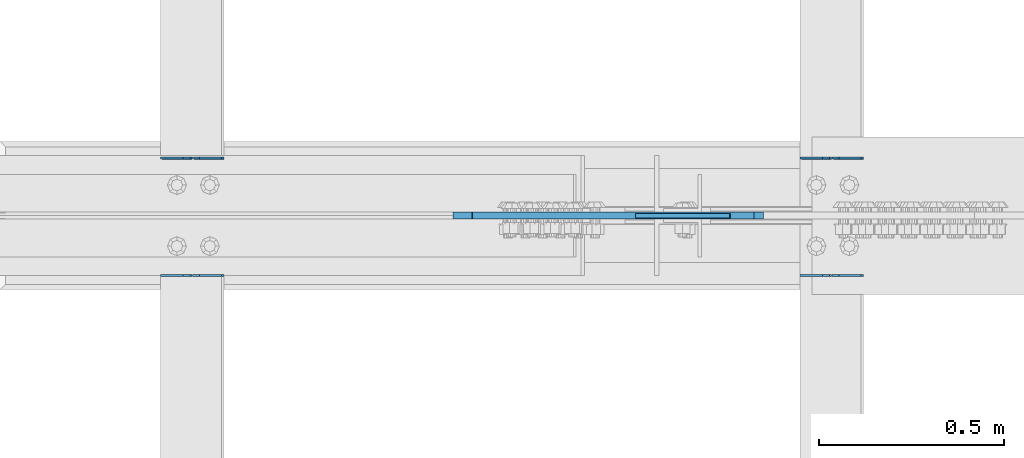
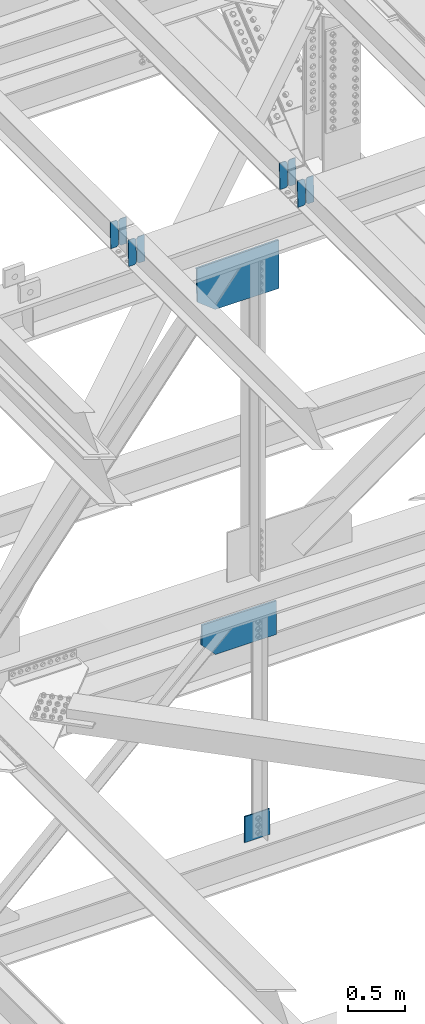
# One storey, part 3603 of 3843: 11 plates, 7 elements without a shape of their own.
"""IFC2X3 building model written with IfcOpenShell, lengths in millimetres."""

from ifc_helpers import new_model, si_unit, frame, origin_with_axes, place, context, subcontext, project, spatial, faceted_brep, material, type_object, element, aggregate, save


model = new_model("IFC2X3")

# Units and contexts
model_context = context("Model", 3, precision=1e-05, world=origin_with_axes())
body_context = subcontext(model_context, "Body", "Model", "MODEL_VIEW")
ifc_project = project(units=[si_unit("LENGTHUNIT", "METRE", prefix="MILLI"), si_unit("AREAUNIT", "SQUARE_METRE"), si_unit("VOLUMEUNIT", "CUBIC_METRE"), si_unit("MASSUNIT", "GRAM", prefix="KILO"), si_unit("TIMEUNIT", "SECOND"), si_unit("PLANEANGLEUNIT", "RADIAN"), si_unit("SOLIDANGLEUNIT", "STERADIAN"), si_unit("THERMODYNAMICTEMPERATUREUNIT", "DEGREE_CELSIUS"), si_unit("LUMINOUSINTENSITYUNIT", "LUMEN")], contexts=[model_context])

# Site, building, storey
site_placement = place(None, origin_with_axes())
site = spatial("IfcSite", under=ifc_project, at=site_placement, CompositionType="ELEMENT")
building_placement = place(site_placement, origin_with_axes())
building = spatial("IfcBuilding", under=site, at=building_placement, Name="Undefined", CompositionType="ELEMENT")
storey_placement = place(building_placement, origin_with_axes())
storey = spatial("IfcBuildingStorey", under=building, at=storey_placement, Name="Undefined", CompositionType="ELEMENT", Elevation=0.0)

# Assembly, plates
assembly_1_placement = place(storey_placement, origin_with_axes())
assembly_1 = element("IfcElementAssembly", 1, at=assembly_1_placement, inside=storey, Name="BEAM", AssemblyPlace="NOTDEFINED", PredefinedType="RIGID_FRAME")
ifc_material = material(Name="STEEL/A572-50")
plate_type_1 = type_object("IfcPlateType", PredefinedType="NOTDEFINED")
plate_1_placement = place(assembly_1_placement, frame((80549.4964818022, 59070.6862808835, 46449.4723570783), z_axis=(-0.0211520982257644, 0.00063245100018685, 0.999776069300711), x_axis=(-0.999776269350183, -1.43399999262055e-05, -0.021152093007418)))
plate_1 = element("IfcPlate", 2, at=plate_1_placement, type_object=plate_type_1, material=ifc_material, Name="PLATE", context=body_context, shape_type="Brep", body=[
    faceted_brep([(0.0, -3.17499999999927, 0.0), (6.83940015733242e-10, -3.17499999996653, 288.924999998613), (6.54836185276508e-10, 3.17500000001746, 288.924999998591), (0.0, 3.17499999999927, 0.0), (60.3250007643655, -3.17500000017753, 288.924999998606), (60.3250007643219, 3.17499999979918, 288.924999998584), (79.3750000013097, -3.17500000025029, 269.875000761494), (79.375000001266, 3.17499999972642, 269.875000761487), (79.375000000713, -3.17500000026484, 19.0499992370605), (79.3750000006985, 3.17499999971187, 19.0499992370533), (60.325000763667, -3.17500000020664, -1.45519152283669e-11), (60.3250007636234, 3.17499999977736, -3.63797880709171e-11)], [[[0, 1, 2, 3]], [[1, 4, 5, 2]], [[4, 6, 7, 5]], [[6, 8, 9, 7]], [[8, 10, 11, 9]], [[10, 0, 3, 11]], [[5, 7, 9, 11, 3, 2]], [[10, 8, 6, 4, 1, 0]]]),
])
plate_2_placement = place(assembly_1_placement, frame((80463.7906611109, 59070.6851357132, 46447.6590938386), z_axis=(-0.0211520982257644, 0.00063245100018685, 0.999776069300711), x_axis=(-0.999776269350183, -1.43399999262055e-05, -0.021152093007418)))
plate_2 = element("IfcPlate", 3, at=plate_2_placement, type_object=plate_type_1, material=ifc_material, Name="PLATE", context=body_context, shape_type="Brep", body=[
    faceted_brep([(4.36557456851006e-11, -3.17499999998836, 19.0499992370969), (6.11180439591408e-10, -3.17499999996653, 269.875000761516), (5.96628524363041e-10, 3.17500000001746, 269.875000761502), (1.45519152283669e-11, 3.17499999998836, 19.0499992370824), (19.0499992376572, -3.17500000003201, 288.924999998606), (19.0499992376281, 3.1749999999447, 288.924999998584), (79.3750000013242, -3.17500000025029, 288.924999998591), (79.3750000013097, 3.1749999997337, 288.92499999857), (79.3750000006548, -3.17500000026484, -2.18278728425503e-11), (79.3750000006403, 3.17499999969732, -2.91038304567337e-11), (19.0499992370023, -3.17500000005384, 0.0), (19.0499992369587, 3.17499999992287, -1.45519152283669e-11)], [[[0, 1, 2, 3]], [[1, 4, 5, 2]], [[4, 6, 7, 5]], [[6, 8, 9, 7]], [[8, 10, 11, 9]], [[10, 0, 3, 11]], [[5, 7, 9, 11, 3, 2]], [[10, 8, 6, 4, 1, 0]]]),
])
aggregate(assembly_1, [plate_1, plate_2])

assembly_2_placement = place(storey_placement, origin_with_axes())
assembly_2 = element("IfcElementAssembly", 4, at=assembly_2_placement, inside=storey, Name="BEAM", AssemblyPlace="NOTDEFINED", PredefinedType="RIGID_FRAME")
plate_3_placement = place(assembly_2_placement, frame((80549.4964783693, 58753.5631013965, 46449.4695674323), z_axis=(-0.021152098138482, -0.000624861000040255, 0.999776074075125), x_axis=(-0.999776269355722, 1.23390000256453e-05, -0.0211520940075457)))
plate_3 = element("IfcPlate", 5, at=plate_3_placement, type_object=plate_type_1, material=ifc_material, Name="PLATE", context=body_context, shape_type="Brep", body=[
    faceted_brep([(0.0, -3.17499999999927, 0.0), (6.83940015733242e-10, -3.17499999996653, 288.924999998613), (6.54836185276508e-10, 3.17500000001746, 288.924999998591), (0.0, 3.17499999999927, 0.0), (60.3250007643655, -3.17500000017753, 288.924999998606), (60.3250007643219, 3.17499999979918, 288.924999998584), (79.3750000013097, -3.17500000025029, 269.875000761494), (79.375000001266, 3.17499999972642, 269.875000761487), (79.375000000713, -3.17500000026484, 19.0499992370605), (79.3750000006985, 3.17499999971187, 19.0499992370533), (60.325000763667, -3.17500000020664, -1.45519152283669e-11), (60.3250007636234, 3.17499999977736, -3.63797880709171e-11)], [[[0, 1, 2, 3]], [[1, 4, 5, 2]], [[4, 6, 7, 5]], [[6, 8, 9, 7]], [[8, 10, 11, 9]], [[10, 0, 3, 11]], [[5, 7, 9, 11, 3, 2]], [[10, 8, 6, 4, 1, 0]]]),
])
plate_4_placement = place(assembly_2_placement, frame((80463.7906576781, 58753.564234688, 46447.6563041856), z_axis=(-0.021152098138482, -0.000624861000040255, 0.999776074075125), x_axis=(-0.999776269355722, 1.23390000256453e-05, -0.0211520940075457)))
plate_4 = element("IfcPlate", 6, at=plate_4_placement, type_object=plate_type_1, material=ifc_material, Name="PLATE", context=body_context, shape_type="Brep", body=[
    faceted_brep([(4.36557456851006e-11, -3.17499999998836, 19.0499992370969), (6.11180439591408e-10, -3.17499999996653, 269.875000761516), (5.96628524363041e-10, 3.17500000001746, 269.875000761502), (1.45519152283669e-11, 3.17499999998836, 19.0499992370824), (19.0499992376572, -3.17500000003201, 288.924999998606), (19.0499992376281, 3.1749999999447, 288.924999998584), (79.3750000013242, -3.17500000025029, 288.924999998591), (79.3750000013097, 3.1749999997337, 288.92499999857), (79.3750000006548, -3.17500000026484, -2.18278728425503e-11), (79.3750000006403, 3.17499999969732, -2.91038304567337e-11), (19.0499992370023, -3.17500000005384, 0.0), (19.0499992369587, 3.17499999992287, -1.45519152283669e-11)], [[[0, 1, 2, 3]], [[1, 4, 5, 2]], [[4, 6, 7, 5]], [[6, 8, 9, 7]], [[8, 10, 11, 9]], [[10, 0, 3, 11]], [[5, 7, 9, 11, 3, 2]], [[10, 8, 6, 4, 1, 0]]]),
])
aggregate(assembly_2, [plate_3, plate_4])

assembly_3_placement = place(storey_placement, origin_with_axes())
assembly_3 = element("IfcElementAssembly", 7, at=assembly_3_placement, inside=storey, Name="BEAM", AssemblyPlace="NOTDEFINED", PredefinedType="RIGID_FRAME")
plate_5_placement = place(assembly_3_placement, frame((78822.2964818254, 59070.6940089604, 46415.5716852855), z_axis=(-0.0211520978869958, 0.000606560000211177, 0.999776085351088), x_axis=(-0.999776269355723, -1.23390000258365e-05, -0.0211520940075068)))
plate_5 = element("IfcPlate", 8, at=plate_5_placement, type_object=plate_type_1, material=ifc_material, Name="PLATE", context=body_context, shape_type="Brep", body=[
    faceted_brep([(0.0, -3.17499999999927, 0.0), (6.83940015733242e-10, -3.17499999996653, 288.924999998613), (6.54836185276508e-10, 3.17500000001746, 288.924999998591), (0.0, 3.17499999999927, 0.0), (60.3250007643655, -3.17500000017753, 288.924999998606), (60.3250007643219, 3.17499999979918, 288.924999998584), (79.3750000013097, -3.17500000025029, 269.875000761494), (79.375000001266, 3.17499999972642, 269.875000761487), (79.375000000713, -3.17500000026484, 19.0499992370605), (79.3750000006985, 3.17499999971187, 19.0499992370533), (60.325000763667, -3.17500000020664, -1.45519152283669e-11), (60.3250007636234, 3.17499999977736, -3.63797880709171e-11)], [[[0, 1, 2, 3]], [[1, 4, 5, 2]], [[4, 6, 7, 5]], [[6, 8, 9, 7]], [[8, 10, 11, 9]], [[10, 0, 3, 11]], [[5, 7, 9, 11, 3, 2]], [[10, 8, 6, 4, 1, 0]]]),
])
plate_6_placement = place(assembly_3_placement, frame((78736.5906611341, 59070.6929107476, 46413.758422016), z_axis=(-0.0211520978869958, 0.000606560000211177, 0.999776085351088), x_axis=(-0.999776269355723, -1.23390000258365e-05, -0.0211520940075068)))
plate_6 = element("IfcPlate", 9, at=plate_6_placement, type_object=plate_type_1, material=ifc_material, Name="PLATE", context=body_context, shape_type="Brep", body=[
    faceted_brep([(4.36557456851006e-11, -3.17499999998836, 19.0499992370969), (6.11180439591408e-10, -3.17499999996653, 269.875000761516), (5.96628524363041e-10, 3.17500000001746, 269.875000761502), (1.45519152283669e-11, 3.17499999998836, 19.0499992370824), (19.0499992376572, -3.17500000003201, 288.924999998606), (19.0499992376281, 3.1749999999447, 288.924999998584), (79.3750000013242, -3.17500000025029, 288.924999998591), (79.3750000013097, 3.1749999997337, 288.92499999857), (79.3750000006548, -3.17500000026484, -2.18278728425503e-11), (79.3750000006403, 3.17499999969732, -2.91038304567337e-11), (19.0499992370023, -3.17500000005384, 0.0), (19.0499992369587, 3.17499999992287, -1.45519152283669e-11)], [[[0, 1, 2, 3]], [[1, 4, 5, 2]], [[4, 6, 7, 5]], [[6, 8, 9, 7]], [[8, 10, 11, 9]], [[10, 0, 3, 11]], [[5, 7, 9, 11, 3, 2]], [[10, 8, 6, 4, 1, 0]]]),
])
aggregate(assembly_3, [plate_5, plate_6])

assembly_4_placement = place(storey_placement, origin_with_axes())
assembly_4 = element("IfcElementAssembly", 10, at=assembly_4_placement, inside=storey, Name="BEAM", AssemblyPlace="NOTDEFINED", PredefinedType="RIGID_FRAME")
plate_7_placement = place(assembly_4_placement, frame((78822.2964783698, 58753.5266743956, 46415.5837070154), z_axis=(-0.021152097741724, -0.000508339000058186, 0.99977614011967), x_axis=(-0.999776269357268, 1.0337000006824e-05, -0.0211520950075907)))
plate_7 = element("IfcPlate", 11, at=plate_7_placement, type_object=plate_type_1, material=ifc_material, Name="PLATE", context=body_context, shape_type="Brep", body=[
    faceted_brep([(0.0, -3.17499999999927, 0.0), (6.83940015733242e-10, -3.17499999996653, 288.924999998613), (6.54836185276508e-10, 3.17500000001746, 288.924999998591), (0.0, 3.17499999999927, 0.0), (60.3250007643655, -3.17500000017753, 288.924999998606), (60.3250007643219, 3.17499999979918, 288.924999998584), (79.3750000013097, -3.17500000025029, 269.875000761494), (79.375000001266, 3.17499999972642, 269.875000761487), (79.375000000713, -3.17500000026484, 19.0499992370605), (79.3750000006985, 3.17499999971187, 19.0499992370533), (60.325000763667, -3.17500000020664, -1.45519152283669e-11), (60.3250007636234, 3.17499999977736, -3.63797880709171e-11)], [[[0, 1, 2, 3]], [[1, 4, 5, 2]], [[4, 6, 7, 5]], [[6, 8, 9, 7]], [[8, 10, 11, 9]], [[10, 0, 3, 11]], [[5, 7, 9, 11, 3, 2]], [[10, 8, 6, 4, 1, 0]]]),
])
plate_8_placement = place(assembly_4_placement, frame((78736.5906576786, 58753.5275963541, 46413.770443649), z_axis=(-0.021152097741724, -0.000508339000058186, 0.99977614011967), x_axis=(-0.999776269357268, 1.0337000006824e-05, -0.0211520950075907)))
plate_8 = element("IfcPlate", 12, at=plate_8_placement, type_object=plate_type_1, material=ifc_material, Name="PLATE", context=body_context, shape_type="Brep", body=[
    faceted_brep([(4.36557456851006e-11, -3.17499999998836, 19.0499992370969), (6.11180439591408e-10, -3.17499999996653, 269.875000761516), (5.96628524363041e-10, 3.17500000001746, 269.875000761502), (1.45519152283669e-11, 3.17499999998836, 19.0499992370824), (19.0499992376572, -3.17500000003201, 288.924999998606), (19.0499992376281, 3.1749999999447, 288.924999998584), (79.3750000013242, -3.17500000025029, 288.924999998591), (79.3750000013097, 3.1749999997337, 288.92499999857), (79.3750000006548, -3.17500000026484, -2.18278728425503e-11), (79.3750000006403, 3.17499999969732, -2.91038304567337e-11), (19.0499992370023, -3.17500000005384, 0.0), (19.0499992369587, 3.17499999992287, -1.45519152283669e-11)], [[[0, 1, 2, 3]], [[1, 4, 5, 2]], [[4, 6, 7, 5]], [[6, 8, 9, 7]], [[8, 10, 11, 9]], [[10, 0, 3, 11]], [[5, 7, 9, 11, 3, 2]], [[10, 8, 6, 4, 1, 0]]]),
])
aggregate(assembly_4, [plate_7, plate_8])

# Assembly, plate
assembly_5_placement = place(storey_placement, origin_with_axes())
assembly_5 = element("IfcElementAssembly", 13, at=assembly_5_placement, inside=storey, Name="BEAM", AssemblyPlace="NOTDEFINED", PredefinedType="RIGID_FRAME")
plate_type_2 = type_object("IfcPlateType", PredefinedType="NOTDEFINED")
plate_9_placement = place(assembly_5_placement, frame((80279.4954825506, 58915.3, 46039.2903585868), z_axis=(0.0191252529927733, 0.0, -0.999817095621976), x_axis=(-0.999817095621976, 0.0, -0.0191252529927674)))
plate_9 = element("IfcPlate", 14, at=plate_9_placement, type_object=plate_type_2, material=ifc_material, Name="PLATE", context=body_context, shape_type="Brep", body=[
    faceted_brep([(0.0, -9.52500000000146, 0.0), (9.636566826739, -9.52500000000146, 523.617760637841), (9.636566826739, 9.52500000000146, 523.617760637841), (0.0, 9.52500000000146, 0.0), (661.023736043833, -9.52500000000146, 511.157537448904), (661.023736043833, 9.52500000000146, 511.157537448904), (838.228057231056, -9.52500000000146, 366.739433427843), (838.228057231056, 9.52500000000146, 366.739433427843), (838.228057230386, -9.52500000000146, -1.20780896395445e-09), (838.228057230386, 9.52500000000146, -1.20780896395445e-09)], [[[0, 1, 2, 3]], [[1, 4, 5, 2]], [[4, 6, 7, 5]], [[6, 8, 9, 7]], [[8, 0, 3, 9]], [[5, 7, 9, 3, 2]], [[8, 6, 4, 1, 0]]]),
])
aggregate(assembly_5, [plate_9])

assembly_6_placement = place(storey_placement, origin_with_axes())
assembly_6 = element("IfcElementAssembly", 15, at=assembly_6_placement, inside=storey, Name="BEAM", AssemblyPlace="NOTDEFINED", PredefinedType="RIGID_FRAME")
plate_type_3 = type_object("IfcPlateType", PredefinedType="NOTDEFINED")
plate_10_placement = place(assembly_6_placement, frame((80254.4766041645, 58915.3, 42152.4391227326), z_axis=(-0.00202086100011366, 0.0, -0.999997958058324), x_axis=(-0.999997958058324, 0.0, 0.00202086100011715)))
plate_10 = element("IfcPlate", 16, at=plate_10_placement, type_object=plate_type_3, material=ifc_material, Name="PLATE", context=body_context, shape_type="Brep", body=[
    faceted_brep([(0.0, -9.52500000000146, 0.0), (-0.731130305459374, -9.52500000000146, 362.584599088834), (-0.731130305459374, 9.52500000000146, 362.584599088834), (0.0, 9.52500000000146, 0.0), (621.037847735905, -9.52500000000146, 363.181308734034), (621.037847735905, 9.52500000000146, 363.181308734034), (761.525667838927, -9.52500000000146, 215.616435646261), (761.525667838927, 9.52500000000146, 215.616435646261), (761.525667840455, -9.52500000000146, -1.67347025126219e-10), (761.525667840455, 9.52500000000146, -1.67347025126219e-10)], [[[0, 1, 2, 3]], [[1, 4, 5, 2]], [[4, 6, 7, 5]], [[6, 8, 9, 7]], [[8, 0, 3, 9]], [[5, 7, 9, 3, 2]], [[8, 6, 4, 1, 0]]]),
])
aggregate(assembly_6, [plate_10])

assembly_7_placement = place(storey_placement, origin_with_axes())
assembly_7 = element("IfcElementAssembly", 17, at=assembly_7_placement, inside=storey, Name="BEAM", AssemblyPlace="NOTDEFINED", PredefinedType="RIGID_FRAME")
plate_type_4 = type_object("IfcPlateType", PredefinedType="NOTDEFINED")
plate_11_placement = place(assembly_7_placement, frame((80190.2308091335, 58915.3000007629, 39652.6115278145), z_axis=(-0.00872114900049929, 0.0, 0.999961970056917), x_axis=(-0.999961970056917, 0.0, -0.00872114900049944)))
plate_11 = element("IfcPlate", 18, at=plate_11_placement, type_object=plate_type_4, material=ifc_material, Name="PLATE", context=body_context, shape_type="Brep", body=[
    faceted_brep([(0.0, -6.3499999046162, 0.0), (5.96628524363041e-10, -6.34999999999854, 278.725788829892), (5.96628524363041e-10, 6.34999999999854, 278.725788829892), (7.27595761418343e-12, 6.3499999046162, 0.0), (253.99034043483, -6.34999999999854, 280.940960675805), (253.99034043483, 6.34999999999854, 280.940960675805), (256.440561594383, -6.34999999999854, -5.60248736292124e-10), (256.440561594383, 6.34999999999854, -5.60248736292124e-10)], [[[0, 1, 2, 3]], [[1, 4, 5, 2]], [[4, 6, 7, 5]], [[6, 0, 3, 7]], [[5, 7, 3, 2]], [[6, 4, 1, 0]]]),
])
aggregate(assembly_7, [plate_11])

save(model, "model.ifc")
